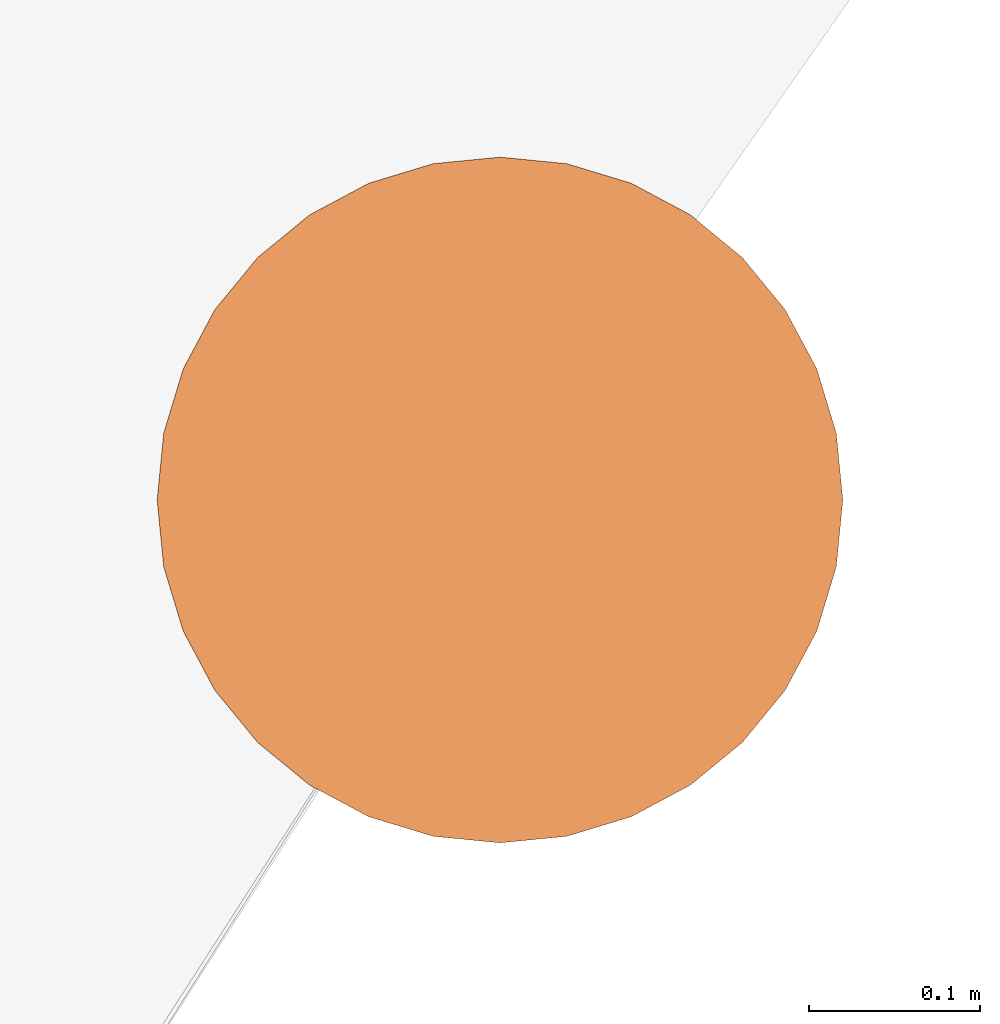
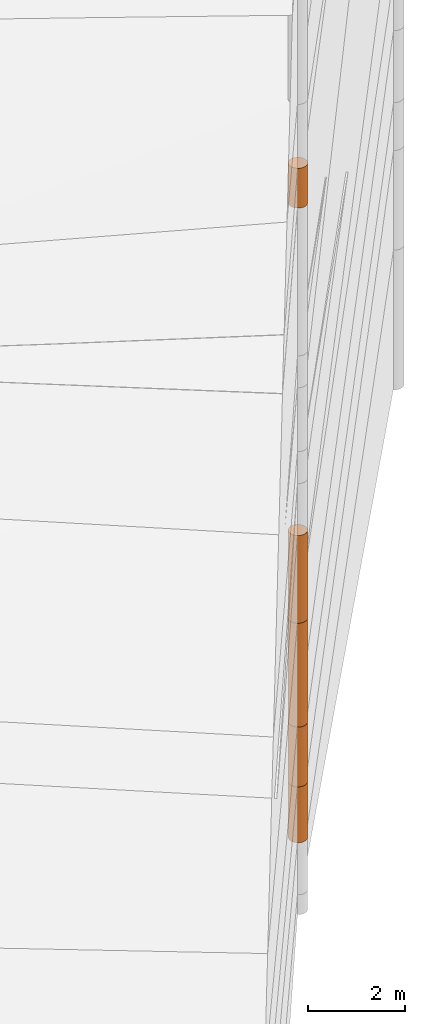
# One storey, part 15 of 24: 5 geographic elements.
"""IFC4 building model written with IfcOpenShell, lengths in metres."""

from ifc_helpers import new_model, entity, si_unit, converted_unit, frame, origin_with_axes, origin_2d_with_axis, place, context, subcontext, project, spatial, polygons, element, save


model = new_model("IFC4")

# Units and contexts
model_context = context("Model", 3, precision=1e-05, world=origin_with_axes())
plan_context = context("Plan", 2, precision=1e-05, world=origin_2d_with_axis())
body_context = subcontext(model_context, "Body", "Model", "MODEL_VIEW")
ifc_project = project(units=[converted_unit("PLANEANGLEUNIT", "degree", entity("IfcReal", 0.0174532925199433), si_unit("PLANEANGLEUNIT", "RADIAN"), dimensions=[0, 0, 0, 0, 0, 0, 0]), si_unit("AREAUNIT", "SQUARE_METRE"), si_unit("VOLUMEUNIT", "CUBIC_METRE"), si_unit("LENGTHUNIT", "METRE")], contexts=[model_context, plan_context])

# Site, building, storey
site_placement = place(None, origin_with_axes())
site = spatial("IfcSite", under=ifc_project, at=site_placement)
building_placement = place(site_placement, origin_with_axes())
building = spatial("IfcBuilding", under=site, at=building_placement, Name="Building")
storey_placement = place(building_placement, origin_with_axes())
storey = spatial("IfcBuildingStorey", under=building, at=storey_placement, Name="Storey")

# Geographic elements
geographic_element_1_placement = place(storey_placement, frame((36.5, 56.7999992370605, -7.49999952316284), z_axis=(0.0, 0.0, 1.0), x_axis=(1.0, 0.0, 0.0)))
element("IfcGeographicElement", 1, at=geographic_element_1_placement, inside=storey, PredefinedType="NOTDEFINED", context=body_context, shape_type="Tessellation", body=[
    polygons([(0.0, 0.0, -0.699999928474426), (0.0390180610120296, 0.196157038211823, -0.699999928474426), (0.0, 0.199999988079071, -0.699999928474426), (0.0, 0.0, 0.699999928474426), (0.0, 0.199999988079071, 0.699999928474426), (0.0390180610120296, 0.196157038211823, 0.699999928474426), (0.0765366926789284, 0.18477588891983, -0.699999928474426), (0.0765366926789284, 0.18477588891983, 0.699999928474426), (0.111114047467709, 0.166293919086456, -0.699999928474426), (0.111114047467709, 0.166293919086456, 0.699999928474426), (0.141421362757683, 0.141421362757683, -0.699999928474426), (0.141421362757683, 0.141421362757683, 0.699999928474426), (0.166293919086456, 0.111114047467709, -0.699999928474426), (0.166293919086456, 0.111114047467709, 0.699999928474426), (0.18477588891983, 0.0765366926789284, -0.699999928474426), (0.18477588891983, 0.0765366926789284, 0.699999928474426), (0.196157038211823, 0.0390180610120296, -0.699999928474426), (0.196157038211823, 0.0390180610120296, 0.699999928474426), (0.199999988079071, 0.0, -0.699999928474426), (0.199999988079071, 0.0, 0.699999928474426), (0.196157038211823, -0.0390180610120296, -0.699999928474426), (0.196157038211823, -0.0390180610120296, 0.699999928474426), (0.18477588891983, -0.0765366926789284, -0.699999928474426), (0.18477588891983, -0.0765366926789284, 0.699999928474426), (0.166293919086456, -0.111114047467709, -0.699999928474426), (0.166293919086456, -0.111114047467709, 0.699999928474426), (0.141421362757683, -0.141421362757683, -0.699999928474426), (0.141421362757683, -0.141421362757683, 0.699999928474426), (0.111114047467709, -0.166293919086456, -0.699999928474426), (0.111114047467709, -0.166293919086456, 0.699999928474426), (0.0765366926789284, -0.18477588891983, -0.699999928474426), (0.0765366926789284, -0.18477588891983, 0.699999928474426), (0.0390180610120296, -0.196157038211823, -0.699999928474426), (0.0390180610120296, -0.196157038211823, 0.699999928474426), (0.0, -0.199999988079071, -0.699999928474426), (0.0, -0.199999988079071, 0.699999928474426), (-0.0390180610120296, -0.196157038211823, -0.699999928474426), (-0.0390180610120296, -0.196157038211823, 0.699999928474426), (-0.0765366926789284, -0.18477588891983, -0.699999928474426), (-0.0765366926789284, -0.18477588891983, 0.699999928474426), (-0.111114047467709, -0.166293919086456, -0.699999928474426), (-0.111114047467709, -0.166293919086456, 0.699999928474426), (-0.141421362757683, -0.141421362757683, -0.699999928474426), (-0.141421362757683, -0.141421362757683, 0.699999928474426), (-0.166293919086456, -0.111114047467709, -0.699999928474426), (-0.166293919086456, -0.111114047467709, 0.699999928474426), (-0.18477588891983, -0.0765366926789284, -0.699999928474426), (-0.18477588891983, -0.0765366926789284, 0.699999928474426), (-0.196157038211823, -0.0390180610120296, -0.699999928474426), (-0.196157038211823, -0.0390180610120296, 0.699999928474426), (-0.199999988079071, 0.0, -0.699999928474426), (-0.199999988079071, 0.0, 0.699999928474426), (-0.196157038211823, 0.0390180610120296, -0.699999928474426), (-0.196157038211823, 0.0390180610120296, 0.699999928474426), (-0.18477588891983, 0.0765366926789284, -0.699999928474426), (-0.18477588891983, 0.0765366926789284, 0.699999928474426), (-0.166293919086456, 0.111114047467709, -0.699999928474426), (-0.166293919086456, 0.111114047467709, 0.699999928474426), (-0.141421362757683, 0.141421362757683, -0.699999928474426), (-0.141421362757683, 0.141421362757683, 0.699999928474426), (-0.111114047467709, 0.166293919086456, -0.699999928474426), (-0.111114047467709, 0.166293919086456, 0.699999928474426), (-0.0765366926789284, 0.18477588891983, -0.699999928474426), (-0.0765366926789284, 0.18477588891983, 0.699999928474426), (-0.0390180610120296, 0.196157038211823, -0.699999928474426), (-0.0390180610120296, 0.196157038211823, 0.699999928474426)], [[[3, 2, 1]], [[6, 5, 4]], [[28, 30, 29, 27]], [[2, 7, 1]], [[8, 6, 4]], [[36, 38, 37, 35]], [[7, 9, 1]], [[10, 8, 4]], [[56, 58, 57, 55]], [[9, 11, 1]], [[12, 10, 4]], [[58, 60, 59, 57]], [[11, 13, 1]], [[12, 4, 14]], [[54, 56, 55, 53]], [[1, 13, 15]], [[4, 16, 14]], [[10, 12, 11, 9]], [[1, 15, 17]], [[4, 18, 16]], [[60, 62, 61, 59]], [[1, 17, 19]], [[4, 20, 18]], [[16, 18, 17, 15]], [[1, 19, 21]], [[4, 22, 20]], [[18, 20, 19, 17]], [[1, 21, 23]], [[4, 24, 22]], [[20, 22, 21, 19]], [[1, 23, 25]], [[4, 26, 24]], [[22, 24, 23, 21]], [[27, 1, 25]], [[26, 4, 28]], [[24, 26, 25, 23]], [[1, 27, 29]], [[28, 4, 30]], [[62, 64, 63, 61]], [[1, 29, 31]], [[4, 32, 30]], [[64, 66, 65, 63]], [[1, 31, 33]], [[4, 34, 32]], [[30, 32, 31, 29]], [[1, 33, 35]], [[4, 36, 34]], [[8, 10, 9, 7]], [[1, 35, 37]], [[4, 38, 36]], [[32, 34, 33, 31]], [[1, 37, 39]], [[4, 40, 38]], [[6, 8, 7, 2]], [[1, 39, 41]], [[4, 42, 40]], [[38, 40, 39, 37]], [[43, 1, 41]], [[4, 44, 42]], [[40, 42, 41, 39]], [[45, 1, 43]], [[46, 44, 4]], [[42, 44, 43, 41]], [[45, 47, 1]], [[48, 46, 4]], [[44, 46, 45, 43]], [[47, 49, 1]], [[50, 48, 4]], [[46, 48, 47, 45]], [[49, 51, 1]], [[52, 50, 4]], [[48, 50, 49, 47]], [[51, 53, 1]], [[54, 52, 4]], [[66, 5, 3, 65]], [[53, 55, 1]], [[56, 54, 4]], [[52, 54, 53, 51]], [[55, 57, 1]], [[58, 56, 4]], [[57, 59, 1]], [[60, 58, 4]], [[34, 36, 35, 33]], [[59, 61, 1]], [[62, 60, 4]], [[14, 16, 15, 13]], [[61, 63, 1]], [[64, 62, 4]], [[26, 28, 27, 25]], [[63, 65, 1]], [[66, 64, 4]], [[5, 6, 2, 3]], [[65, 3, 1]], [[5, 66, 4]], [[50, 52, 51, 49]], [[12, 14, 13, 11]]]),
])
geographic_element_2_placement = place(storey_placement, frame((36.5, 56.7999992370605, -6.04999971389771), z_axis=(0.0, 0.0, 1.0), x_axis=(1.0, 0.0, 0.0)))
element("IfcGeographicElement", 2, at=geographic_element_2_placement, inside=storey, PredefinedType="NOTDEFINED", context=body_context, shape_type="Tessellation", body=[
    polygons([(0.0, 0.0, -0.749999940395355), (0.0390180610120296, 0.196157038211823, -0.749999940395355), (0.0, 0.199999988079071, -0.749999940395355), (0.0, 0.0, 0.749999940395355), (0.0, 0.199999988079071, 0.749999940395355), (0.0390180610120296, 0.196157038211823, 0.749999940395355), (0.0765366926789284, 0.18477588891983, -0.749999940395355), (0.0765366926789284, 0.18477588891983, 0.749999940395355), (0.111114047467709, 0.166293919086456, -0.749999940395355), (0.111114047467709, 0.166293919086456, 0.749999940395355), (0.141421362757683, 0.141421362757683, -0.749999940395355), (0.141421362757683, 0.141421362757683, 0.749999940395355), (0.166293919086456, 0.111114047467709, -0.749999940395355), (0.166293919086456, 0.111114047467709, 0.749999940395355), (0.18477588891983, 0.0765366926789284, -0.749999940395355), (0.18477588891983, 0.0765366926789284, 0.749999940395355), (0.196157038211823, 0.0390180610120296, -0.749999940395355), (0.196157038211823, 0.0390180610120296, 0.749999940395355), (0.199999988079071, 0.0, -0.749999940395355), (0.199999988079071, 0.0, 0.749999940395355), (0.196157038211823, -0.0390180610120296, -0.749999940395355), (0.196157038211823, -0.0390180610120296, 0.749999940395355), (0.18477588891983, -0.0765366926789284, -0.749999940395355), (0.18477588891983, -0.0765366926789284, 0.749999940395355), (0.166293919086456, -0.111114047467709, -0.749999940395355), (0.166293919086456, -0.111114047467709, 0.749999940395355), (0.141421362757683, -0.141421362757683, -0.749999940395355), (0.141421362757683, -0.141421362757683, 0.749999940395355), (0.111114047467709, -0.166293919086456, -0.749999940395355), (0.111114047467709, -0.166293919086456, 0.749999940395355), (0.0765366926789284, -0.18477588891983, -0.749999940395355), (0.0765366926789284, -0.18477588891983, 0.749999940395355), (0.0390180610120296, -0.196157038211823, -0.749999940395355), (0.0390180610120296, -0.196157038211823, 0.749999940395355), (0.0, -0.199999988079071, -0.749999940395355), (0.0, -0.199999988079071, 0.749999940395355), (-0.0390180610120296, -0.196157038211823, -0.749999940395355), (-0.0390180610120296, -0.196157038211823, 0.749999940395355), (-0.0765366926789284, -0.18477588891983, -0.749999940395355), (-0.0765366926789284, -0.18477588891983, 0.749999940395355), (-0.111114047467709, -0.166293919086456, -0.749999940395355), (-0.111114047467709, -0.166293919086456, 0.749999940395355), (-0.141421362757683, -0.141421362757683, -0.749999940395355), (-0.141421362757683, -0.141421362757683, 0.749999940395355), (-0.166293919086456, -0.111114047467709, -0.749999940395355), (-0.166293919086456, -0.111114047467709, 0.749999940395355), (-0.18477588891983, -0.0765366926789284, -0.749999940395355), (-0.18477588891983, -0.0765366926789284, 0.749999940395355), (-0.196157038211823, -0.0390180610120296, -0.749999940395355), (-0.196157038211823, -0.0390180610120296, 0.749999940395355), (-0.199999988079071, 0.0, -0.749999940395355), (-0.199999988079071, 0.0, 0.749999940395355), (-0.196157038211823, 0.0390180610120296, -0.749999940395355), (-0.196157038211823, 0.0390180610120296, 0.749999940395355), (-0.18477588891983, 0.0765366926789284, -0.749999940395355), (-0.18477588891983, 0.0765366926789284, 0.749999940395355), (-0.166293919086456, 0.111114047467709, -0.749999940395355), (-0.166293919086456, 0.111114047467709, 0.749999940395355), (-0.141421362757683, 0.141421362757683, -0.749999940395355), (-0.141421362757683, 0.141421362757683, 0.749999940395355), (-0.111114047467709, 0.166293919086456, -0.749999940395355), (-0.111114047467709, 0.166293919086456, 0.749999940395355), (-0.0765366926789284, 0.18477588891983, -0.749999940395355), (-0.0765366926789284, 0.18477588891983, 0.749999940395355), (-0.0390180610120296, 0.196157038211823, -0.749999940395355), (-0.0390180610120296, 0.196157038211823, 0.749999940395355)], [[[3, 2, 1]], [[6, 5, 4]], [[28, 30, 29, 27]], [[2, 7, 1]], [[8, 6, 4]], [[36, 38, 37, 35]], [[7, 9, 1]], [[10, 8, 4]], [[56, 58, 57, 55]], [[9, 11, 1]], [[12, 10, 4]], [[58, 60, 59, 57]], [[11, 13, 1]], [[12, 4, 14]], [[54, 56, 55, 53]], [[1, 13, 15]], [[4, 16, 14]], [[10, 12, 11, 9]], [[1, 15, 17]], [[4, 18, 16]], [[60, 62, 61, 59]], [[1, 17, 19]], [[4, 20, 18]], [[16, 18, 17, 15]], [[1, 19, 21]], [[20, 4, 22]], [[18, 20, 19, 17]], [[1, 21, 23]], [[4, 24, 22]], [[20, 22, 21, 19]], [[1, 23, 25]], [[24, 4, 26]], [[22, 24, 23, 21]], [[1, 25, 27]], [[26, 4, 28]], [[24, 26, 25, 23]], [[1, 27, 29]], [[28, 4, 30]], [[62, 64, 63, 61]], [[1, 29, 31]], [[4, 32, 30]], [[64, 66, 65, 63]], [[1, 31, 33]], [[4, 34, 32]], [[30, 32, 31, 29]], [[1, 33, 35]], [[4, 36, 34]], [[8, 10, 9, 7]], [[1, 35, 37]], [[4, 38, 36]], [[32, 34, 33, 31]], [[1, 37, 39]], [[4, 40, 38]], [[6, 8, 7, 2]], [[1, 39, 41]], [[4, 42, 40]], [[38, 40, 39, 37]], [[43, 1, 41]], [[4, 44, 42]], [[40, 42, 41, 39]], [[45, 1, 43]], [[4, 46, 44]], [[42, 44, 43, 41]], [[47, 1, 45]], [[48, 46, 4]], [[44, 46, 45, 43]], [[47, 49, 1]], [[50, 48, 4]], [[46, 48, 47, 45]], [[51, 1, 49]], [[52, 50, 4]], [[48, 50, 49, 47]], [[51, 53, 1]], [[4, 54, 52]], [[66, 5, 3, 65]], [[53, 55, 1]], [[56, 54, 4]], [[52, 54, 53, 51]], [[55, 57, 1]], [[4, 58, 56]], [[59, 1, 57]], [[60, 58, 4]], [[34, 36, 35, 33]], [[59, 61, 1]], [[62, 60, 4]], [[14, 16, 15, 13]], [[61, 63, 1]], [[64, 62, 4]], [[26, 28, 27, 25]], [[63, 65, 1]], [[66, 64, 4]], [[5, 6, 2, 3]], [[65, 3, 1]], [[5, 66, 4]], [[50, 52, 51, 49]], [[12, 14, 13, 11]]]),
])
geographic_element_3_placement = place(storey_placement, frame((36.5, 56.7999992370605, -3.99999976158142), z_axis=(0.0, 0.0, 1.0), x_axis=(1.0, 0.0, 0.0)))
element("IfcGeographicElement", 3, at=geographic_element_3_placement, inside=storey, PredefinedType="NOTDEFINED", context=body_context, shape_type="Tessellation", body=[
    polygons([(0.0, 0.0, -1.29999983310699), (0.0390180610120296, 0.196157038211823, -1.29999983310699), (0.0, 0.199999988079071, -1.29999983310699), (0.0, 0.0, 1.29999983310699), (0.0, 0.199999988079071, 1.29999983310699), (0.0390180610120296, 0.196157038211823, 1.29999983310699), (0.0765366926789284, 0.18477588891983, -1.29999983310699), (0.0765366926789284, 0.18477588891983, 1.29999983310699), (0.111114047467709, 0.166293919086456, -1.29999983310699), (0.111114047467709, 0.166293919086456, 1.29999983310699), (0.141421362757683, 0.141421362757683, -1.29999983310699), (0.141421362757683, 0.141421362757683, 1.29999983310699), (0.166293919086456, 0.111114047467709, -1.29999983310699), (0.166293919086456, 0.111114047467709, 1.29999983310699), (0.18477588891983, 0.0765366926789284, -1.29999983310699), (0.18477588891983, 0.0765366926789284, 1.29999983310699), (0.196157038211823, 0.0390180610120296, -1.29999983310699), (0.196157038211823, 0.0390180610120296, 1.29999983310699), (0.199999988079071, 0.0, -1.29999983310699), (0.199999988079071, 0.0, 1.29999983310699), (0.196157038211823, -0.0390180610120296, -1.29999983310699), (0.196157038211823, -0.0390180610120296, 1.29999983310699), (0.18477588891983, -0.0765366926789284, -1.29999983310699), (0.18477588891983, -0.0765366926789284, 1.29999983310699), (0.166293919086456, -0.111114047467709, -1.29999983310699), (0.166293919086456, -0.111114047467709, 1.29999983310699), (0.141421362757683, -0.141421362757683, -1.29999983310699), (0.141421362757683, -0.141421362757683, 1.29999983310699), (0.111114047467709, -0.166293919086456, -1.29999983310699), (0.111114047467709, -0.166293919086456, 1.29999983310699), (0.0765366926789284, -0.18477588891983, -1.29999983310699), (0.0765366926789284, -0.18477588891983, 1.29999983310699), (0.0390180610120296, -0.196157038211823, -1.29999983310699), (0.0390180610120296, -0.196157038211823, 1.29999983310699), (0.0, -0.199999988079071, -1.29999983310699), (0.0, -0.199999988079071, 1.29999983310699), (-0.0390180610120296, -0.196157038211823, -1.29999983310699), (-0.0390180610120296, -0.196157038211823, 1.29999983310699), (-0.0765366926789284, -0.18477588891983, -1.29999983310699), (-0.0765366926789284, -0.18477588891983, 1.29999983310699), (-0.111114047467709, -0.166293919086456, -1.29999983310699), (-0.111114047467709, -0.166293919086456, 1.29999983310699), (-0.141421362757683, -0.141421362757683, -1.29999983310699), (-0.141421362757683, -0.141421362757683, 1.29999983310699), (-0.166293919086456, -0.111114047467709, -1.29999983310699), (-0.166293919086456, -0.111114047467709, 1.29999983310699), (-0.18477588891983, -0.0765366926789284, -1.29999983310699), (-0.18477588891983, -0.0765366926789284, 1.29999983310699), (-0.196157038211823, -0.0390180610120296, -1.29999983310699), (-0.196157038211823, -0.0390180610120296, 1.29999983310699), (-0.199999988079071, 0.0, -1.29999983310699), (-0.199999988079071, 0.0, 1.29999983310699), (-0.196157038211823, 0.0390180610120296, -1.29999983310699), (-0.196157038211823, 0.0390180610120296, 1.29999983310699), (-0.18477588891983, 0.0765366926789284, -1.29999983310699), (-0.18477588891983, 0.0765366926789284, 1.29999983310699), (-0.166293919086456, 0.111114047467709, -1.29999983310699), (-0.166293919086456, 0.111114047467709, 1.29999983310699), (-0.141421362757683, 0.141421362757683, -1.29999983310699), (-0.141421362757683, 0.141421362757683, 1.29999983310699), (-0.111114047467709, 0.166293919086456, -1.29999983310699), (-0.111114047467709, 0.166293919086456, 1.29999983310699), (-0.0765366926789284, 0.18477588891983, -1.29999983310699), (-0.0765366926789284, 0.18477588891983, 1.29999983310699), (-0.0390180610120296, 0.196157038211823, -1.29999983310699), (-0.0390180610120296, 0.196157038211823, 1.29999983310699)], [[[3, 2, 1]], [[6, 5, 4]], [[32, 34, 33, 31]], [[2, 7, 1]], [[8, 6, 4]], [[64, 66, 65, 63]], [[7, 9, 1]], [[10, 8, 4]], [[9, 11, 1]], [[12, 10, 4]], [[40, 42, 41, 39]], [[1, 11, 13]], [[12, 4, 14]], [[10, 12, 11, 9]], [[1, 13, 15]], [[4, 16, 14]], [[12, 14, 13, 11]], [[1, 15, 17]], [[4, 18, 16]], [[18, 20, 19, 17]], [[1, 17, 19]], [[18, 4, 20]], [[20, 22, 21, 19]], [[1, 19, 21]], [[20, 4, 22]], [[22, 24, 23, 21]], [[1, 21, 23]], [[4, 24, 22]], [[54, 56, 55, 53]], [[1, 23, 25]], [[4, 26, 24]], [[56, 58, 57, 55]], [[27, 1, 25]], [[4, 28, 26]], [[24, 26, 25, 23]], [[1, 27, 29]], [[28, 4, 30]], [[26, 28, 27, 25]], [[1, 29, 31]], [[4, 32, 30]], [[46, 48, 47, 45]], [[1, 31, 33]], [[4, 34, 32]], [[36, 38, 37, 35]], [[1, 33, 35]], [[4, 36, 34]], [[42, 44, 43, 41]], [[1, 35, 37]], [[4, 38, 36]], [[38, 40, 39, 37]], [[1, 37, 39]], [[4, 40, 38]], [[34, 36, 35, 33]], [[1, 39, 41]], [[4, 42, 40]], [[8, 10, 9, 7]], [[43, 1, 41]], [[4, 44, 42]], [[44, 46, 45, 43]], [[43, 45, 1]], [[46, 44, 4]], [[30, 32, 31, 29]], [[45, 47, 1]], [[48, 46, 4]], [[28, 30, 29, 27]], [[47, 49, 1]], [[50, 48, 4]], [[5, 6, 2, 3]], [[51, 1, 49]], [[4, 52, 50]], [[48, 50, 49, 47]], [[53, 1, 51]], [[4, 54, 52]], [[50, 52, 51, 49]], [[53, 55, 1]], [[56, 54, 4]], [[52, 54, 53, 51]], [[55, 57, 1]], [[58, 56, 4]], [[58, 60, 59, 57]], [[57, 59, 1]], [[60, 58, 4]], [[60, 62, 61, 59]], [[59, 61, 1]], [[62, 60, 4]], [[62, 64, 63, 61]], [[61, 63, 1]], [[64, 62, 4]], [[14, 16, 15, 13]], [[63, 65, 1]], [[66, 64, 4]], [[16, 18, 17, 15]], [[65, 3, 1]], [[5, 66, 4]], [[6, 8, 7, 2]], [[66, 5, 3, 65]]]),
])
geographic_element_4_placement = place(storey_placement, frame((36.5, 56.7999992370605, -1.59999990463257), z_axis=(0.0, 0.0, 1.0), x_axis=(1.0, 0.0, 0.0)))
element("IfcGeographicElement", 4, at=geographic_element_4_placement, inside=storey, PredefinedType="NOTDEFINED", context=body_context, shape_type="Tessellation", body=[
    polygons([(0.0, 0.0, -1.10000002384186), (0.0390180610120296, 0.196157038211823, -1.10000002384186), (0.0, 0.199999988079071, -1.10000002384186), (0.0, 0.0, 1.10000002384186), (0.0, 0.199999988079071, 1.10000002384186), (0.0390180610120296, 0.196157038211823, 1.10000002384186), (0.0765366926789284, 0.18477588891983, -1.10000002384186), (0.0765366926789284, 0.18477588891983, 1.10000002384186), (0.111114047467709, 0.166293919086456, -1.10000002384186), (0.111114047467709, 0.166293919086456, 1.10000002384186), (0.141421362757683, 0.141421362757683, -1.10000002384186), (0.141421362757683, 0.141421362757683, 1.10000002384186), (0.166293919086456, 0.111114047467709, -1.10000002384186), (0.166293919086456, 0.111114047467709, 1.10000002384186), (0.18477588891983, 0.0765366926789284, -1.10000002384186), (0.18477588891983, 0.0765366926789284, 1.10000002384186), (0.196157038211823, 0.0390180610120296, -1.10000002384186), (0.196157038211823, 0.0390180610120296, 1.10000002384186), (0.199999988079071, 0.0, -1.10000002384186), (0.199999988079071, 0.0, 1.10000002384186), (0.196157038211823, -0.0390180610120296, -1.10000002384186), (0.196157038211823, -0.0390180610120296, 1.10000002384186), (0.18477588891983, -0.0765366926789284, -1.10000002384186), (0.18477588891983, -0.0765366926789284, 1.10000002384186), (0.166293919086456, -0.111114047467709, -1.10000002384186), (0.166293919086456, -0.111114047467709, 1.10000002384186), (0.141421362757683, -0.141421362757683, -1.10000002384186), (0.141421362757683, -0.141421362757683, 1.10000002384186), (0.111114047467709, -0.166293919086456, -1.10000002384186), (0.111114047467709, -0.166293919086456, 1.10000002384186), (0.0765366926789284, -0.18477588891983, -1.10000002384186), (0.0765366926789284, -0.18477588891983, 1.10000002384186), (0.0390180610120296, -0.196157038211823, -1.10000002384186), (0.0390180610120296, -0.196157038211823, 1.10000002384186), (0.0, -0.199999988079071, -1.10000002384186), (0.0, -0.199999988079071, 1.10000002384186), (-0.0390180610120296, -0.196157038211823, -1.10000002384186), (-0.0390180610120296, -0.196157038211823, 1.10000002384186), (-0.0765366926789284, -0.18477588891983, -1.10000002384186), (-0.0765366926789284, -0.18477588891983, 1.10000002384186), (-0.111114047467709, -0.166293919086456, -1.10000002384186), (-0.111114047467709, -0.166293919086456, 1.10000002384186), (-0.141421362757683, -0.141421362757683, -1.10000002384186), (-0.141421362757683, -0.141421362757683, 1.10000002384186), (-0.166293919086456, -0.111114047467709, -1.10000002384186), (-0.166293919086456, -0.111114047467709, 1.10000002384186), (-0.18477588891983, -0.0765366926789284, -1.10000002384186), (-0.18477588891983, -0.0765366926789284, 1.10000002384186), (-0.196157038211823, -0.0390180610120296, -1.10000002384186), (-0.196157038211823, -0.0390180610120296, 1.10000002384186), (-0.199999988079071, 0.0, -1.10000002384186), (-0.199999988079071, 0.0, 1.10000002384186), (-0.196157038211823, 0.0390180610120296, -1.10000002384186), (-0.196157038211823, 0.0390180610120296, 1.10000002384186), (-0.18477588891983, 0.0765366926789284, -1.10000002384186), (-0.18477588891983, 0.0765366926789284, 1.10000002384186), (-0.166293919086456, 0.111114047467709, -1.10000002384186), (-0.166293919086456, 0.111114047467709, 1.10000002384186), (-0.141421362757683, 0.141421362757683, -1.10000002384186), (-0.141421362757683, 0.141421362757683, 1.10000002384186), (-0.111114047467709, 0.166293919086456, -1.10000002384186), (-0.111114047467709, 0.166293919086456, 1.10000002384186), (-0.0765366926789284, 0.18477588891983, -1.10000002384186), (-0.0765366926789284, 0.18477588891983, 1.10000002384186), (-0.0390180610120296, 0.196157038211823, -1.10000002384186), (-0.0390180610120296, 0.196157038211823, 1.10000002384186)], [[[3, 2, 1]], [[6, 5, 4]], [[28, 30, 29, 27]], [[2, 7, 1]], [[8, 6, 4]], [[64, 66, 65, 63]], [[7, 9, 1]], [[10, 8, 4]], [[10, 12, 11, 9]], [[9, 11, 1]], [[12, 10, 4]], [[11, 13, 1]], [[12, 4, 14]], [[66, 5, 3, 65]], [[1, 13, 15]], [[14, 4, 16]], [[34, 36, 35, 33]], [[1, 15, 17]], [[16, 4, 18]], [[14, 16, 15, 13]], [[1, 17, 19]], [[4, 20, 18]], [[32, 34, 33, 31]], [[1, 19, 21]], [[4, 22, 20]], [[50, 52, 51, 49]], [[1, 21, 23]], [[4, 24, 22]], [[20, 22, 21, 19]], [[1, 23, 25]], [[24, 4, 26]], [[22, 24, 23, 21]], [[1, 25, 27]], [[26, 4, 28]], [[60, 62, 61, 59]], [[1, 27, 29]], [[28, 4, 30]], [[26, 28, 27, 25]], [[1, 29, 31]], [[4, 32, 30]], [[6, 8, 7, 2]], [[1, 31, 33]], [[4, 34, 32]], [[42, 44, 43, 41]], [[1, 33, 35]], [[4, 36, 34]], [[8, 10, 9, 7]], [[1, 35, 37]], [[4, 38, 36]], [[16, 18, 17, 15]], [[1, 37, 39]], [[4, 40, 38]], [[36, 38, 37, 35]], [[1, 39, 41]], [[4, 42, 40]], [[38, 40, 39, 37]], [[43, 1, 41]], [[4, 44, 42]], [[40, 42, 41, 39]], [[45, 1, 43]], [[4, 46, 44]], [[18, 20, 19, 17]], [[47, 1, 45]], [[4, 48, 46]], [[44, 46, 45, 43]], [[47, 49, 1]], [[4, 50, 48]], [[46, 48, 47, 45]], [[49, 51, 1]], [[52, 50, 4]], [[48, 50, 49, 47]], [[51, 53, 1]], [[54, 52, 4]], [[24, 26, 25, 23]], [[55, 1, 53]], [[56, 54, 4]], [[52, 54, 53, 51]], [[57, 1, 55]], [[4, 58, 56]], [[54, 56, 55, 53]], [[59, 1, 57]], [[60, 58, 4]], [[56, 58, 57, 55]], [[59, 61, 1]], [[62, 60, 4]], [[58, 60, 59, 57]], [[61, 63, 1]], [[64, 62, 4]], [[5, 6, 2, 3]], [[63, 65, 1]], [[66, 64, 4]], [[62, 64, 63, 61]], [[65, 3, 1]], [[5, 66, 4]], [[30, 32, 31, 29]], [[12, 14, 13, 11]]]),
])
geographic_element_5_placement = place(storey_placement, frame((36.5, 56.7999992370605, 8.20000076293945), z_axis=(0.0, 0.0, 1.0), x_axis=(1.0, 0.0, 0.0)))
element("IfcGeographicElement", 5, at=geographic_element_5_placement, inside=storey, PredefinedType="NOTDEFINED", context=body_context, shape_type="Tessellation", body=[
    polygons([(0.0, 0.0, -0.499999970197678), (0.0390180610120296, 0.196157038211823, -0.499999970197678), (0.0, 0.199999988079071, -0.499999970197678), (0.0, 0.0, 0.499999970197678), (0.0, 0.199999988079071, 0.499999970197678), (0.0390180610120296, 0.196157038211823, 0.499999970197678), (0.0765366926789284, 0.18477588891983, -0.499999970197678), (0.0765366926789284, 0.18477588891983, 0.499999970197678), (0.111114047467709, 0.166293919086456, -0.499999970197678), (0.111114047467709, 0.166293919086456, 0.499999970197678), (0.141421362757683, 0.141421362757683, -0.499999970197678), (0.141421362757683, 0.141421362757683, 0.499999970197678), (0.166293919086456, 0.111114047467709, -0.499999970197678), (0.166293919086456, 0.111114047467709, 0.499999970197678), (0.18477588891983, 0.0765366926789284, -0.499999970197678), (0.18477588891983, 0.0765366926789284, 0.499999970197678), (0.196157038211823, 0.0390180610120296, -0.499999970197678), (0.196157038211823, 0.0390180610120296, 0.499999970197678), (0.199999988079071, 0.0, -0.499999970197678), (0.199999988079071, 0.0, 0.499999970197678), (0.196157038211823, -0.0390180610120296, -0.499999970197678), (0.196157038211823, -0.0390180610120296, 0.499999970197678), (0.18477588891983, -0.0765366926789284, -0.499999970197678), (0.18477588891983, -0.0765366926789284, 0.499999970197678), (0.166293919086456, -0.111114047467709, -0.499999970197678), (0.166293919086456, -0.111114047467709, 0.499999970197678), (0.141421362757683, -0.141421362757683, -0.499999970197678), (0.141421362757683, -0.141421362757683, 0.499999970197678), (0.111114047467709, -0.166293919086456, -0.499999970197678), (0.111114047467709, -0.166293919086456, 0.499999970197678), (0.0765366926789284, -0.18477588891983, -0.499999970197678), (0.0765366926789284, -0.18477588891983, 0.499999970197678), (0.0390180610120296, -0.196157038211823, -0.499999970197678), (0.0390180610120296, -0.196157038211823, 0.499999970197678), (0.0, -0.199999988079071, -0.499999970197678), (0.0, -0.199999988079071, 0.499999970197678), (-0.0390180610120296, -0.196157038211823, -0.499999970197678), (-0.0390180610120296, -0.196157038211823, 0.499999970197678), (-0.0765366926789284, -0.18477588891983, -0.499999970197678), (-0.0765366926789284, -0.18477588891983, 0.499999970197678), (-0.111114047467709, -0.166293919086456, -0.499999970197678), (-0.111114047467709, -0.166293919086456, 0.499999970197678), (-0.141421362757683, -0.141421362757683, -0.499999970197678), (-0.141421362757683, -0.141421362757683, 0.499999970197678), (-0.166293919086456, -0.111114047467709, -0.499999970197678), (-0.166293919086456, -0.111114047467709, 0.499999970197678), (-0.18477588891983, -0.0765366926789284, -0.499999970197678), (-0.18477588891983, -0.0765366926789284, 0.499999970197678), (-0.196157038211823, -0.0390180610120296, -0.499999970197678), (-0.196157038211823, -0.0390180610120296, 0.499999970197678), (-0.199999988079071, 0.0, -0.499999970197678), (-0.199999988079071, 0.0, 0.499999970197678), (-0.196157038211823, 0.0390180610120296, -0.499999970197678), (-0.196157038211823, 0.0390180610120296, 0.499999970197678), (-0.18477588891983, 0.0765366926789284, -0.499999970197678), (-0.18477588891983, 0.0765366926789284, 0.499999970197678), (-0.166293919086456, 0.111114047467709, -0.499999970197678), (-0.166293919086456, 0.111114047467709, 0.499999970197678), (-0.141421362757683, 0.141421362757683, -0.499999970197678), (-0.141421362757683, 0.141421362757683, 0.499999970197678), (-0.111114047467709, 0.166293919086456, -0.499999970197678), (-0.111114047467709, 0.166293919086456, 0.499999970197678), (-0.0765366926789284, 0.18477588891983, -0.499999970197678), (-0.0765366926789284, 0.18477588891983, 0.499999970197678), (-0.0390180610120296, 0.196157038211823, -0.499999970197678), (-0.0390180610120296, 0.196157038211823, 0.499999970197678)], [[[3, 2, 1]], [[6, 5, 4]], [[28, 30, 29, 27]], [[2, 7, 1]], [[8, 6, 4]], [[64, 66, 65, 63]], [[7, 9, 1]], [[10, 8, 4]], [[9, 11, 1]], [[12, 10, 4]], [[6, 8, 7, 2]], [[1, 11, 13]], [[12, 4, 14]], [[66, 5, 3, 65]], [[1, 13, 15]], [[4, 16, 14]], [[12, 14, 13, 11]], [[1, 15, 17]], [[16, 4, 18]], [[14, 16, 15, 13]], [[1, 17, 19]], [[4, 20, 18]], [[16, 18, 17, 15]], [[1, 19, 21]], [[20, 4, 22]], [[18, 20, 19, 17]], [[1, 21, 23]], [[22, 4, 24]], [[20, 22, 21, 19]], [[1, 23, 25]], [[24, 4, 26]], [[22, 24, 23, 21]], [[27, 1, 25]], [[4, 28, 26]], [[24, 26, 25, 23]], [[1, 27, 29]], [[28, 4, 30]], [[26, 28, 27, 25]], [[1, 29, 31]], [[4, 32, 30]], [[5, 6, 2, 3]], [[1, 31, 33]], [[4, 34, 32]], [[30, 32, 31, 29]], [[1, 33, 35]], [[4, 36, 34]], [[8, 10, 9, 7]], [[1, 35, 37]], [[4, 38, 36]], [[32, 34, 33, 31]], [[1, 37, 39]], [[4, 40, 38]], [[36, 38, 37, 35]], [[1, 39, 41]], [[4, 42, 40]], [[38, 40, 39, 37]], [[43, 1, 41]], [[4, 44, 42]], [[40, 42, 41, 39]], [[43, 45, 1]], [[46, 44, 4]], [[42, 44, 43, 41]], [[47, 1, 45]], [[48, 46, 4]], [[44, 46, 45, 43]], [[49, 1, 47]], [[4, 50, 48]], [[46, 48, 47, 45]], [[51, 1, 49]], [[52, 50, 4]], [[48, 50, 49, 47]], [[51, 53, 1]], [[4, 54, 52]], [[50, 52, 51, 49]], [[55, 1, 53]], [[4, 56, 54]], [[52, 54, 53, 51]], [[55, 57, 1]], [[4, 58, 56]], [[54, 56, 55, 53]], [[57, 59, 1]], [[60, 58, 4]], [[56, 58, 57, 55]], [[59, 61, 1]], [[62, 60, 4]], [[58, 60, 59, 57]], [[61, 63, 1]], [[64, 62, 4]], [[60, 62, 61, 59]], [[63, 65, 1]], [[66, 64, 4]], [[62, 64, 63, 61]], [[65, 3, 1]], [[5, 66, 4]], [[34, 36, 35, 33]], [[10, 12, 11, 9]]]),
])

save(model, "model.ifc")
